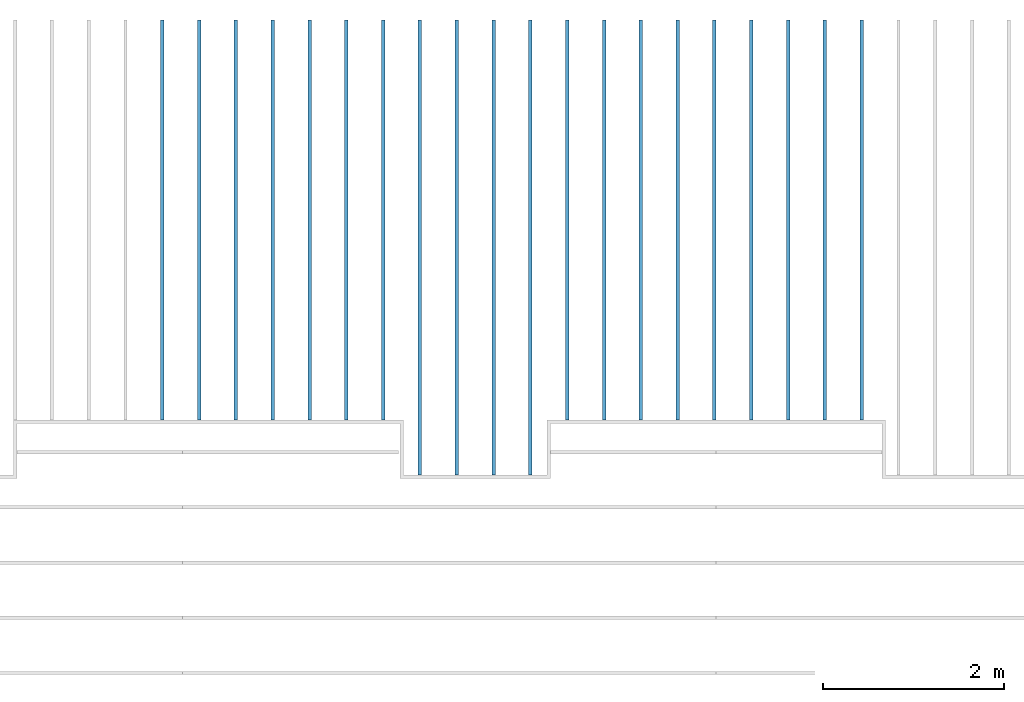
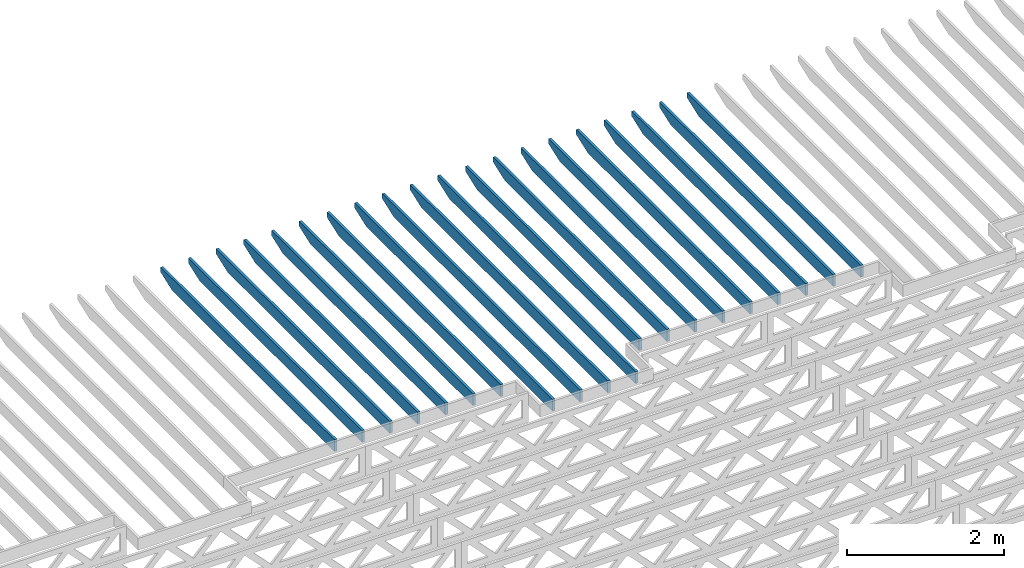
# One storey, part 6 of 17: 20 beams, 1 element without a shape of its own.
"""IFC4 building model written with IfcOpenShell, lengths in feet."""

from ifc_helpers import new_model, entity, si_unit, converted_unit, derived_unit, direction, frame, frame_2d, origin, place, context, subcontext, project, spatial, rectangle, extrude, clip, halfspace, source, transform, mapped, material, material_profile, profile_set, profile_usage, type_object, type_shapes, element, aggregate, save


model = new_model("IFC4")

# Units and contexts
model_context = context("Model", 3, precision=0.0001, world=origin(), true_north=direction((6.12303176911189e-17, 1.0)))
body_context = subcontext(model_context, "Body", "Model", "MODEL_VIEW")
ifc_project = project(units=[converted_unit("LENGTHUNIT", "FOOT", entity("IfcRatioMeasure", 0.3048), si_unit("LENGTHUNIT", "METRE"), dimensions=[1, 0, 0, 0, 0, 0, 0]), converted_unit("AREAUNIT", "SQUARE FOOT", entity("IfcRatioMeasure", 0.09290304), si_unit("AREAUNIT", "SQUARE_METRE"), dimensions=[2, 0, 0, 0, 0, 0, 0]), converted_unit("VOLUMEUNIT", "CUBIC FOOT", entity("IfcRatioMeasure", 0.028316846592), si_unit("VOLUMEUNIT", "CUBIC_METRE"), dimensions=[3, 0, 0, 0, 0, 0, 0]), converted_unit("PLANEANGLEUNIT", "DEGREE", entity("IfcRatioMeasure", 0.0174532925199433), si_unit("PLANEANGLEUNIT", "RADIAN"), dimensions=[0, 0, 0, 0, 0, 0, 0]), si_unit("MASSUNIT", "GRAM", prefix="KILO"), derived_unit("MASSDENSITYUNIT", [(si_unit("MASSUNIT", "GRAM", prefix="KILO"), 1), (si_unit("LENGTHUNIT", "METRE"), -3)]), derived_unit("MOMENTOFINERTIAUNIT", [(si_unit("LENGTHUNIT", "METRE"), 4)]), si_unit("TIMEUNIT", "SECOND"), si_unit("FREQUENCYUNIT", "HERTZ"), si_unit("THERMODYNAMICTEMPERATUREUNIT", "DEGREE_CELSIUS"), derived_unit("THERMALTRANSMITTANCEUNIT", [(si_unit("MASSUNIT", "GRAM", prefix="KILO"), 1), (si_unit("THERMODYNAMICTEMPERATUREUNIT", "KELVIN"), -1), (si_unit("TIMEUNIT", "SECOND"), -3)]), derived_unit("VOLUMETRICFLOWRATEUNIT", [(si_unit("LENGTHUNIT", "METRE"), 3), (si_unit("TIMEUNIT", "SECOND"), -1)]), si_unit("ELECTRICCURRENTUNIT", "AMPERE"), si_unit("ELECTRICVOLTAGEUNIT", "VOLT"), si_unit("POWERUNIT", "WATT"), si_unit("FORCEUNIT", "NEWTON"), si_unit("ILLUMINANCEUNIT", "LUX"), si_unit("LUMINOUSFLUXUNIT", "LUMEN"), si_unit("LUMINOUSINTENSITYUNIT", "CANDELA"), derived_unit("USERDEFINED", [(si_unit("MASSUNIT", "GRAM", prefix="KILO"), -1), (si_unit("LENGTHUNIT", "METRE"), -2), (si_unit("TIMEUNIT", "SECOND"), 3), (si_unit("LUMINOUSFLUXUNIT", "LUMEN"), 1)]), derived_unit("LINEARVELOCITYUNIT", [(si_unit("LENGTHUNIT", "METRE"), 1), (si_unit("TIMEUNIT", "SECOND"), -1)]), si_unit("PRESSUREUNIT", "PASCAL"), derived_unit("USERDEFINED", [(si_unit("LENGTHUNIT", "METRE"), -2), (si_unit("MASSUNIT", "GRAM", prefix="KILO"), 1), (si_unit("TIMEUNIT", "SECOND"), -2)]), derived_unit("LINEARFORCEUNIT", [(si_unit("MASSUNIT", "GRAM", prefix="KILO"), 1), (si_unit("LENGTHUNIT", "METRE"), 1), (si_unit("TIMEUNIT", "SECOND"), -2), (si_unit("LENGTHUNIT", "METRE"), -1)]), derived_unit("PLANARFORCEUNIT", [(si_unit("MASSUNIT", "GRAM", prefix="KILO"), 1), (si_unit("LENGTHUNIT", "METRE"), 1), (si_unit("TIMEUNIT", "SECOND"), -2), (si_unit("LENGTHUNIT", "METRE"), -2)])], contexts=[model_context])

# Site, building, storey
site_placement = place(None, origin())
site = spatial("IfcSite", under=ifc_project, at=site_placement, CompositionType="ELEMENT")
building_placement = place(site_placement, origin())
building = spatial("IfcBuilding", under=site, at=building_placement, CompositionType="ELEMENT")
storey_placement = place(building_placement, frame((0.0, 0.0, 30.4375000000082)))
storey = spatial("IfcBuildingStorey", under=building, at=storey_placement, Name="ROOF", CompositionType="ELEMENT", Elevation=30.4375000000082)

# Assembly, beams
assembly_placement = place(storey_placement, origin())
assembly = element("IfcElementAssembly", 1, at=assembly_placement, inside=storey, Name="Structural Beam System:Structural Framing System", ObjectType="Structural Beam System:Structural Framing System", AssemblyPlace="NOTDEFINED", PredefinedType="BEAM_GRID")
ifc_material = material(Name="2X ROOF JOISTS - EXT. STAIN-1 - SEE LIFE SAFETY", Category="Materials")
ifc_material_profile = material_profile(ifc_material, rectangle(XDim=0.604166666666667, YDim=0.125000000000011, at=frame_2d((0.0, 0.0), x_axis=(0.0, 1.0))))
ifc_profile_set = profile_set([ifc_material_profile])
ifc_profile_usage_1 = profile_usage(ifc_profile_set, cardinal=8)
beam_type_1 = type_object("IfcBeamType", PredefinedType="BEAM", material=ifc_profile_set)
shared_shape_1 = source(origin(), body_context, "Body", "Clipping", [
    clip(extrude(rectangle(XDim=0.604166666666667, YDim=0.125000000000011, at=frame_2d((0.0, 0.0), x_axis=(0.0, 1.0))), frame((-8.24296473987818, 0.0, 0.0), z_axis=(1.0, 0.0, 0.0), x_axis=(0.0, 1.0, 0.0)), (0.0, 0.0, 1.0), 16.4859294797564), halfspace(frame((-7.26989982048795, -0.0625000000000026, -0.30208333333334), z_axis=(-0.34202014332567, 0.0, -0.939692620785908), x_axis=(0.0, 1.0, 0.0)), False)),
])
type_shapes(beam_type_1, [shared_shape_1])
beam_1_placement = place(assembly_placement, frame((-229.133993818795, 965.271566289195, 1.07291666665833), z_axis=(0.0, 0.0, 1.0), x_axis=(0.0, -1.0, 0.0)))
beam_1 = element("IfcBeam", 2, at=beam_1_placement, type_object=beam_type_1, material=ifc_profile_usage_1, PredefinedType="BEAM", context=body_context, shape_type="MappedRepresentation", body=[
    mapped(shared_shape_1, transform((0.0, 0.0, 0.0), scale=1.0)),
])
ifc_profile_usage_2 = profile_usage(ifc_profile_set, cardinal=8)
beam_2_placement = place(assembly_placement, frame((-230.467327152128, 965.271566289195, 1.07291666665833), z_axis=(0.0, 0.0, 1.0), x_axis=(0.0, -1.0, 0.0)))
beam_2 = element("IfcBeam", 3, at=beam_2_placement, type_object=beam_type_1, material=ifc_profile_usage_2, PredefinedType="BEAM", context=body_context, shape_type="MappedRepresentation", body=[
    mapped(shared_shape_1, transform((0.0, 0.0, 0.0), scale=1.0)),
])
ifc_profile_usage_3 = profile_usage(ifc_profile_set, cardinal=8)
beam_3_placement = place(assembly_placement, frame((-231.800660485462, 965.271566289195, 1.07291666665833), z_axis=(0.0, 0.0, 1.0), x_axis=(0.0, -1.0, 0.0)))
beam_3 = element("IfcBeam", 4, at=beam_3_placement, type_object=beam_type_1, material=ifc_profile_usage_3, PredefinedType="BEAM", context=body_context, shape_type="MappedRepresentation", body=[
    mapped(shared_shape_1, transform((0.0, 0.0, 0.0), scale=1.0)),
])
ifc_profile_usage_4 = profile_usage(ifc_profile_set, cardinal=8)
beam_4_placement = place(assembly_placement, frame((-233.133993818795, 965.271566289195, 1.07291666665833), z_axis=(0.0, 0.0, 1.0), x_axis=(0.0, -1.0, 0.0)))
beam_4 = element("IfcBeam", 5, at=beam_4_placement, type_object=beam_type_1, material=ifc_profile_usage_4, PredefinedType="BEAM", context=body_context, shape_type="MappedRepresentation", body=[
    mapped(shared_shape_1, transform((0.0, 0.0, 0.0), scale=1.0)),
])
ifc_profile_usage_5 = profile_usage(ifc_profile_set, cardinal=8)
beam_type_2 = type_object("IfcBeamType", PredefinedType="BEAM", material=ifc_profile_set)
shared_shape_2 = source(origin(), body_context, "Body", "Clipping", [
    clip(extrude(rectangle(XDim=0.604166666666667, YDim=0.125000000000011, at=frame_2d((0.0, 0.0), x_axis=(0.0, 1.0))), frame((-7.24296361464559, 0.0, 0.0), z_axis=(1.0, 0.0, 0.0), x_axis=(0.0, 1.0, 0.0)), (0.0, 0.0, 1.0), 14.4859272292912), halfspace(frame((-6.26989869525536, -0.0625000000000026, -0.30208333333334), z_axis=(-0.34202014332567, 0.0, -0.939692620785908), x_axis=(0.0, 1.0, 0.0)), False)),
])
type_shapes(beam_type_2, [shared_shape_2])
beam_5_placement = place(assembly_placement, frame((-221.133993818795, 966.271567408975, 1.07291666665832), z_axis=(0.0, 0.0, 1.0), x_axis=(0.0, -1.0, 0.0)))
beam_5 = element("IfcBeam", 6, at=beam_5_placement, type_object=beam_type_2, material=ifc_profile_usage_5, PredefinedType="BEAM", context=body_context, shape_type="MappedRepresentation", body=[
    mapped(shared_shape_2, transform((0.0, 0.0, 0.0), scale=1.0)),
])
ifc_profile_usage_6 = profile_usage(ifc_profile_set, cardinal=8)
beam_type_3 = type_object("IfcBeamType", PredefinedType="BEAM", material=ifc_profile_set)
shared_shape_3 = source(origin(), body_context, "Body", "Clipping", [
    clip(extrude(rectangle(XDim=0.604166666666667, YDim=0.125000000000011, at=frame_2d((0.0, 0.0), x_axis=(0.0, 1.0))), frame((-7.24296378214677, 0.0, 0.0), z_axis=(1.0, 0.0, 0.0), x_axis=(0.0, 1.0, 0.0)), (0.0, 0.0, 1.0), 14.4859275642935), halfspace(frame((-6.26989886275655, -0.0625000000000026, -0.30208333333334), z_axis=(-0.34202014332567, 0.0, -0.939692620785908), x_axis=(0.0, 1.0, 0.0)), False)),
])
type_shapes(beam_type_3, [shared_shape_3])
beam_6_placement = place(assembly_placement, frame((-222.467327152128, 966.271567258212, 1.07291666665832), z_axis=(0.0, 0.0, 1.0), x_axis=(0.0, -1.0, 0.0)))
beam_6 = element("IfcBeam", 7, at=beam_6_placement, type_object=beam_type_3, material=ifc_profile_usage_6, PredefinedType="BEAM", context=body_context, shape_type="MappedRepresentation", body=[
    mapped(shared_shape_3, transform((0.0, 0.0, 0.0), scale=1.0)),
])
ifc_profile_usage_7 = profile_usage(ifc_profile_set, cardinal=8)
beam_type_4 = type_object("IfcBeamType", PredefinedType="BEAM", material=ifc_profile_set)
shared_shape_4 = source(origin(), body_context, "Body", "Clipping", [
    clip(extrude(rectangle(XDim=0.604166666666667, YDim=0.125000000000011, at=frame_2d((0.0, 0.0), x_axis=(0.0, 1.0))), frame((-7.24296317045162, 0.0, 0.0), z_axis=(1.0, 0.0, 0.0), x_axis=(0.0, 1.0, 0.0)), (0.0, 0.0, 1.0), 14.4859263409032), halfspace(frame((-6.26989825106139, -0.0625000000000026, -0.30208333333334), z_axis=(-0.34202014332567, 0.0, -0.939692620785908), x_axis=(0.0, 1.0, 0.0)), False)),
])
type_shapes(beam_type_4, [shared_shape_4])
beam_7_placement = place(assembly_placement, frame((-217.133993818795, 966.271567861263, 1.07291666665832), z_axis=(0.0, 0.0, 1.0), x_axis=(0.0, -1.0, 0.0)))
beam_7 = element("IfcBeam", 8, at=beam_7_placement, type_object=beam_type_4, material=ifc_profile_usage_7, PredefinedType="BEAM", context=body_context, shape_type="MappedRepresentation", body=[
    mapped(shared_shape_4, transform((0.0, 0.0, 0.0), scale=1.0)),
])
ifc_profile_usage_8 = profile_usage(ifc_profile_set, cardinal=8)
beam_type_5 = type_object("IfcBeamType", PredefinedType="BEAM", material=ifc_profile_set)
shared_shape_5 = source(origin(), body_context, "Body", "Clipping", [
    clip(extrude(rectangle(XDim=0.604166666666667, YDim=0.125000000000011, at=frame_2d((0.0, 0.0), x_axis=(0.0, 1.0))), frame((-7.24296332054621, 0.0, 0.0), z_axis=(1.0, 0.0, 0.0), x_axis=(0.0, 1.0, 0.0)), (0.0, 0.0, 1.0), 14.4859266410924), halfspace(frame((-6.26989840115598, -0.0625000000000026, -0.30208333333334), z_axis=(-0.34202014332567, 0.0, -0.939692620785908), x_axis=(0.0, 1.0, 0.0)), False)),
])
type_shapes(beam_type_5, [shared_shape_5])
beam_8_placement = place(assembly_placement, frame((-218.467327152128, 966.2715677105, 1.07291666665832), z_axis=(0.0, 0.0, 1.0), x_axis=(0.0, -1.0, 0.0)))
beam_8 = element("IfcBeam", 9, at=beam_8_placement, type_object=beam_type_5, material=ifc_profile_usage_8, PredefinedType="BEAM", context=body_context, shape_type="MappedRepresentation", body=[
    mapped(shared_shape_5, transform((0.0, 0.0, 0.0), scale=1.0)),
])
ifc_profile_usage_9 = profile_usage(ifc_profile_set, cardinal=8)
beam_type_6 = type_object("IfcBeamType", PredefinedType="BEAM", material=ifc_profile_set)
shared_shape_6 = source(origin(), body_context, "Body", "Clipping", [
    clip(extrude(rectangle(XDim=0.604166666666667, YDim=0.125000000000011, at=frame_2d((0.0, -5.55111512312578e-17), x_axis=(0.0, 1.0))), frame((-7.24296347064075, 0.0, 0.0), z_axis=(1.0, 0.0, 0.0), x_axis=(0.0, 1.0, 0.0)), (0.0, 0.0, 1.0), 14.4859269412815), halfspace(frame((-6.26989855125052, -0.0625000000000026, -0.30208333333334), z_axis=(-0.34202014332567, 0.0, -0.939692620785908), x_axis=(0.0, 1.0, 0.0)), False)),
])
type_shapes(beam_type_6, [shared_shape_6])
beam_9_placement = place(assembly_placement, frame((-219.800660485462, 966.271567559738, 1.07291666665832), z_axis=(0.0, 0.0, 1.0), x_axis=(0.0, -1.0, 0.0)))
beam_9 = element("IfcBeam", 10, at=beam_9_placement, type_object=beam_type_6, material=ifc_profile_usage_9, PredefinedType="BEAM", context=body_context, shape_type="MappedRepresentation", body=[
    mapped(shared_shape_6, transform((0.0, 0.0, 0.0), scale=1.0)),
])
ifc_profile_usage_10 = profile_usage(ifc_profile_set, cardinal=8)
beam_type_7 = type_object("IfcBeamType", PredefinedType="BEAM", material=ifc_profile_set)
shared_shape_7 = source(origin(), body_context, "Body", "Clipping", [
    clip(extrude(rectangle(XDim=0.604166666666667, YDim=0.125000000000011, at=frame_2d((0.0, 0.0), x_axis=(0.0, 1.0))), frame((-7.24296392092435, 0.0, 0.0), z_axis=(1.0, 0.0, 0.0), x_axis=(0.0, 1.0, 0.0)), (0.0, 0.0, 1.0), 14.4859278418487), halfspace(frame((-6.26989900153413, -0.0625000000000026, -0.30208333333334), z_axis=(-0.34202014332567, 0.0, -0.939692620785908), x_axis=(0.0, 1.0, 0.0)), False)),
])
type_shapes(beam_type_7, [shared_shape_7])
beam_10_placement = place(assembly_placement, frame((-223.800660485462, 966.27156710745, 1.07291666665832), z_axis=(0.0, 0.0, 1.0), x_axis=(0.0, -1.0, 0.0)))
beam_10 = element("IfcBeam", 11, at=beam_10_placement, type_object=beam_type_7, material=ifc_profile_usage_10, PredefinedType="BEAM", context=body_context, shape_type="MappedRepresentation", body=[
    mapped(shared_shape_7, transform((0.0, 0.0, 0.0), scale=1.0)),
])
ifc_profile_usage_11 = profile_usage(ifc_profile_set, cardinal=8)
beam_type_8 = type_object("IfcBeamType", PredefinedType="BEAM", material=ifc_profile_set)
shared_shape_8 = source(origin(), body_context, "Body", "Clipping", [
    clip(extrude(rectangle(XDim=0.604166666666667, YDim=0.125000000000011, at=frame_2d((0.0, 0.0), x_axis=(0.0, 1.0))), frame((-7.24296407101895, 0.0, 0.0), z_axis=(1.0, 0.0, 0.0), x_axis=(0.0, 1.0, 0.0)), (0.0, 0.0, 1.0), 14.4859281420379), halfspace(frame((-6.26989915162872, -0.0625000000000026, -0.30208333333334), z_axis=(-0.34202014332567, 0.0, -0.939692620785908), x_axis=(0.0, 1.0, 0.0)), False)),
])
type_shapes(beam_type_8, [shared_shape_8])
beam_11_placement = place(assembly_placement, frame((-225.133993818795, 966.271566956687, 1.07291666665832), z_axis=(0.0, 0.0, 1.0), x_axis=(0.0, -1.0, 0.0)))
beam_11 = element("IfcBeam", 12, at=beam_11_placement, type_object=beam_type_8, material=ifc_profile_usage_11, PredefinedType="BEAM", context=body_context, shape_type="MappedRepresentation", body=[
    mapped(shared_shape_8, transform((0.0, 0.0, 0.0), scale=1.0)),
])
ifc_profile_usage_12 = profile_usage(ifc_profile_set, cardinal=8)
beam_type_9 = type_object("IfcBeamType", PredefinedType="BEAM", material=ifc_profile_set)
shared_shape_9 = source(origin(), body_context, "Body", "Clipping", [
    clip(extrude(rectangle(XDim=0.604166666666667, YDim=0.125000000000011, at=frame_2d((0.0, 0.0), x_axis=(0.0, 1.0))), frame((-7.24296422111348, 0.0, 0.0), z_axis=(1.0, 0.0, 0.0), x_axis=(0.0, 1.0, 0.0)), (0.0, 0.0, 1.0), 14.485928442227), halfspace(frame((-6.26989930172326, -0.0625000000000026, -0.30208333333334), z_axis=(-0.34202014332567, 0.0, -0.939692620785908), x_axis=(0.0, 1.0, 0.0)), False)),
])
type_shapes(beam_type_9, [shared_shape_9])
beam_12_placement = place(assembly_placement, frame((-226.467327152128, 966.271566805925, 1.07291666665832), z_axis=(0.0, 0.0, 1.0), x_axis=(0.0, -1.0, 0.0)))
beam_12 = element("IfcBeam", 13, at=beam_12_placement, type_object=beam_type_9, material=ifc_profile_usage_12, PredefinedType="BEAM", context=body_context, shape_type="MappedRepresentation", body=[
    mapped(shared_shape_9, transform((0.0, 0.0, 0.0), scale=1.0)),
])
ifc_profile_usage_13 = profile_usage(ifc_profile_set, cardinal=8)
beam_type_10 = type_object("IfcBeamType", PredefinedType="BEAM", material=ifc_profile_set)
shared_shape_10 = source(origin(), body_context, "Body", "Clipping", [
    clip(extrude(rectangle(XDim=0.604166666666667, YDim=0.125000000000011, at=frame_2d((0.0, 0.0), x_axis=(0.0, 1.0))), frame((-7.24296437120802, 0.0, 0.0), z_axis=(1.0, 0.0, 0.0), x_axis=(0.0, 1.0, 0.0)), (0.0, 0.0, 1.0), 14.485928742416), halfspace(frame((-6.26989945181779, -0.0625000000000026, -0.30208333333334), z_axis=(-0.34202014332567, 0.0, -0.939692620785908), x_axis=(0.0, 1.0, 0.0)), False)),
])
type_shapes(beam_type_10, [shared_shape_10])
beam_13_placement = place(assembly_placement, frame((-227.800660485462, 966.271566655162, 1.07291666665832), z_axis=(0.0, 0.0, 1.0), x_axis=(0.0, -1.0, 0.0)))
beam_13 = element("IfcBeam", 14, at=beam_13_placement, type_object=beam_type_10, material=ifc_profile_usage_13, PredefinedType="BEAM", context=body_context, shape_type="MappedRepresentation", body=[
    mapped(shared_shape_10, transform((0.0, 0.0, 0.0), scale=1.0)),
])
ifc_profile_usage_14 = profile_usage(ifc_profile_set, cardinal=8)
beam_type_11 = type_object("IfcBeamType", PredefinedType="BEAM", material=ifc_profile_set)
shared_shape_11 = source(origin(), body_context, "Body", "Clipping", [
    clip(extrude(rectangle(XDim=0.604166666666667, YDim=0.125000000000011, at=frame_2d((0.0, 0.0), x_axis=(0.0, 1.0))), frame((-7.2429650122013, 0.0, 0.0), z_axis=(1.0, 0.0, 0.0), x_axis=(0.0, 1.0, 0.0)), (0.0, 0.0, 1.0), 14.4859300244026), halfspace(frame((-6.26990009281107, -0.0625000000000026, -0.30208333333334), z_axis=(-0.34202014332567, 0.0, -0.939692620785908), x_axis=(0.0, 1.0, 0.0)), False)),
])
type_shapes(beam_type_11, [shared_shape_11])
beam_14_placement = place(assembly_placement, frame((-234.467327152128, 966.271566016872, 1.07291666665833), z_axis=(0.0, 0.0, 1.0), x_axis=(0.0, -1.0, 0.0)))
beam_14 = element("IfcBeam", 15, at=beam_14_placement, type_object=beam_type_11, material=ifc_profile_usage_14, PredefinedType="BEAM", context=body_context, shape_type="MappedRepresentation", body=[
    mapped(shared_shape_11, transform((0.0, 0.0, 0.0), scale=1.0)),
])
ifc_profile_usage_15 = profile_usage(ifc_profile_set, cardinal=8)
beam_type_12 = type_object("IfcBeamType", PredefinedType="BEAM", material=ifc_profile_set)
shared_shape_12 = source(origin(), body_context, "Body", "Clipping", [
    clip(extrude(rectangle(XDim=0.604166666666667, YDim=0.125000000000011, at=frame_2d((0.0, 0.0), x_axis=(0.0, 1.0))), frame((-7.24296484470017, 0.0, 0.0), z_axis=(1.0, 0.0, 0.0), x_axis=(0.0, 1.0, 0.0)), (0.0, 0.0, 1.0), 14.4859296894003), halfspace(frame((-6.26989992530994, -0.0625000000000026, -0.30208333333334), z_axis=(-0.34202014332567, 0.0, -0.939692620785908), x_axis=(0.0, 1.0, 0.0)), False)),
])
type_shapes(beam_type_12, [shared_shape_12])
beam_15_placement = place(assembly_placement, frame((-235.800660485462, 966.271566184373, 1.07291666665833), z_axis=(0.0, 0.0, 1.0), x_axis=(0.0, -1.0, 0.0)))
beam_15 = element("IfcBeam", 16, at=beam_15_placement, type_object=beam_type_12, material=ifc_profile_usage_15, PredefinedType="BEAM", context=body_context, shape_type="MappedRepresentation", body=[
    mapped(shared_shape_12, transform((0.0, 0.0, 0.0), scale=1.0)),
])
ifc_profile_usage_16 = profile_usage(ifc_profile_set, cardinal=8)
beam_type_13 = type_object("IfcBeamType", PredefinedType="BEAM", material=ifc_profile_set)
shared_shape_13 = source(origin(), body_context, "Body", "Clipping", [
    clip(extrude(rectangle(XDim=0.604166666666667, YDim=0.125000000000011, at=frame_2d((0.0, 0.0), x_axis=(0.0, 1.0))), frame((-7.24296467719893, 0.0, 0.0), z_axis=(1.0, 0.0, 0.0), x_axis=(0.0, 1.0, 0.0)), (0.0, 0.0, 1.0), 14.4859293543979), halfspace(frame((-6.2698997578087, -0.0625000000000026, -0.30208333333334), z_axis=(-0.34202014332567, 0.0, -0.939692620785908), x_axis=(0.0, 1.0, 0.0)), False)),
])
type_shapes(beam_type_13, [shared_shape_13])
beam_16_placement = place(assembly_placement, frame((-237.133993818795, 966.271566351875, 1.07291666665833), z_axis=(0.0, 0.0, 1.0), x_axis=(0.0, -1.0, 0.0)))
beam_16 = element("IfcBeam", 17, at=beam_16_placement, type_object=beam_type_13, material=ifc_profile_usage_16, PredefinedType="BEAM", context=body_context, shape_type="MappedRepresentation", body=[
    mapped(shared_shape_13, transform((0.0, 0.0, 0.0), scale=1.0)),
])
ifc_profile_usage_17 = profile_usage(ifc_profile_set, cardinal=8)
beam_type_14 = type_object("IfcBeamType", PredefinedType="BEAM", material=ifc_profile_set)
shared_shape_14 = source(origin(), body_context, "Body", "Clipping", [
    clip(extrude(rectangle(XDim=0.604166666666667, YDim=0.125000000000011, at=frame_2d((0.0, 0.0), x_axis=(0.0, 1.0))), frame((-7.2429645096978, 0.0, 0.0), z_axis=(1.0, 0.0, 0.0), x_axis=(0.0, 1.0, 0.0)), (0.0, 0.0, 1.0), 14.4859290193956), halfspace(frame((-6.26989959030757, -0.0625000000000026, -0.30208333333334), z_axis=(-0.34202014332567, 0.0, -0.939692620785908), x_axis=(0.0, 1.0, 0.0)), False)),
])
type_shapes(beam_type_14, [shared_shape_14])
beam_17_placement = place(assembly_placement, frame((-238.467327152128, 966.271566519376, 1.07291666665833), z_axis=(0.0, 0.0, 1.0), x_axis=(0.0, -1.0, 0.0)))
beam_17 = element("IfcBeam", 18, at=beam_17_placement, type_object=beam_type_14, material=ifc_profile_usage_17, PredefinedType="BEAM", context=body_context, shape_type="MappedRepresentation", body=[
    mapped(shared_shape_14, transform((0.0, 0.0, 0.0), scale=1.0)),
])
ifc_profile_usage_18 = profile_usage(ifc_profile_set, cardinal=8)
beam_type_15 = type_object("IfcBeamType", PredefinedType="BEAM", material=ifc_profile_set)
shared_shape_15 = source(origin(), body_context, "Body", "Clipping", [
    clip(extrude(rectangle(XDim=0.604166666666667, YDim=0.125000000000011, at=frame_2d((0.0, -5.55111512312578e-17), x_axis=(0.0, 1.0))), frame((-7.24296434219661, 0.0, 0.0), z_axis=(1.0, 0.0, 0.0), x_axis=(0.0, 1.0, 0.0)), (0.0, 0.0, 1.0), 14.4859286843932), halfspace(frame((-6.26989942280639, -0.0625000000000026, -0.30208333333334), z_axis=(-0.34202014332567, 0.0, -0.939692620785908), x_axis=(0.0, 1.0, 0.0)), False)),
])
type_shapes(beam_type_15, [shared_shape_15])
beam_18_placement = place(assembly_placement, frame((-239.800660485462, 966.271566686877, 1.07291666665833), z_axis=(0.0, 0.0, 1.0), x_axis=(0.0, -1.0, 0.0)))
beam_18 = element("IfcBeam", 19, at=beam_18_placement, type_object=beam_type_15, material=ifc_profile_usage_18, PredefinedType="BEAM", context=body_context, shape_type="MappedRepresentation", body=[
    mapped(shared_shape_15, transform((0.0, 0.0, 0.0), scale=1.0)),
])
ifc_profile_usage_19 = profile_usage(ifc_profile_set, cardinal=8)
beam_type_16 = type_object("IfcBeamType", PredefinedType="BEAM", material=ifc_profile_set)
shared_shape_16 = source(origin(), body_context, "Body", "Clipping", [
    clip(extrude(rectangle(XDim=0.604166666666667, YDim=0.125000000000011, at=frame_2d((0.0, 0.0), x_axis=(0.0, 1.0))), frame((-7.24296417469543, 0.0, 0.0), z_axis=(1.0, 0.0, 0.0), x_axis=(0.0, 1.0, 0.0)), (0.0, 0.0, 1.0), 14.4859283493909), halfspace(frame((-6.2698992553052, -0.0625000000000026, -0.30208333333334), z_axis=(-0.34202014332567, 0.0, -0.939692620785908), x_axis=(0.0, 1.0, 0.0)), False)),
])
type_shapes(beam_type_16, [shared_shape_16])
beam_19_placement = place(assembly_placement, frame((-241.133993818795, 966.271566854378, 1.07291666665833), z_axis=(0.0, 0.0, 1.0), x_axis=(0.0, -1.0, 0.0)))
beam_19 = element("IfcBeam", 20, at=beam_19_placement, type_object=beam_type_16, material=ifc_profile_usage_19, PredefinedType="BEAM", context=body_context, shape_type="MappedRepresentation", body=[
    mapped(shared_shape_16, transform((0.0, 0.0, 0.0), scale=1.0)),
])
ifc_profile_usage_20 = profile_usage(ifc_profile_set, cardinal=8)
beam_type_17 = type_object("IfcBeamType", PredefinedType="BEAM", material=ifc_profile_set)
shared_shape_17 = source(origin(), body_context, "Body", "Clipping", [
    clip(extrude(rectangle(XDim=0.604166666666667, YDim=0.125000000000011, at=frame_2d((0.0, 0.0), x_axis=(0.0, 1.0))), frame((-7.24296400719425, 0.0, 0.0), z_axis=(1.0, 0.0, 0.0), x_axis=(0.0, 1.0, 0.0)), (0.0, 0.0, 1.0), 14.4859280143885), halfspace(frame((-6.26989908780402, -0.0625000000000026, -0.30208333333334), z_axis=(-0.34202014332567, 0.0, -0.939692620785908), x_axis=(0.0, 1.0, 0.0)), False)),
])
type_shapes(beam_type_17, [shared_shape_17])
beam_20_placement = place(assembly_placement, frame((-242.467327152128, 966.271567021879, 1.07291666665833), z_axis=(0.0, 0.0, 1.0), x_axis=(0.0, -1.0, 0.0)))
beam_20 = element("IfcBeam", 21, at=beam_20_placement, type_object=beam_type_17, material=ifc_profile_usage_20, PredefinedType="BEAM", context=body_context, shape_type="MappedRepresentation", body=[
    mapped(shared_shape_17, transform((0.0, 0.0, 0.0), scale=1.0)),
])
aggregate(assembly, [beam_7, beam_8, beam_9, beam_5, beam_6, beam_10, beam_11, beam_12, beam_13, beam_1, beam_2, beam_3, beam_4, beam_14, beam_15, beam_16, beam_17, beam_18, beam_19, beam_20])

save(model, "model.ifc")
